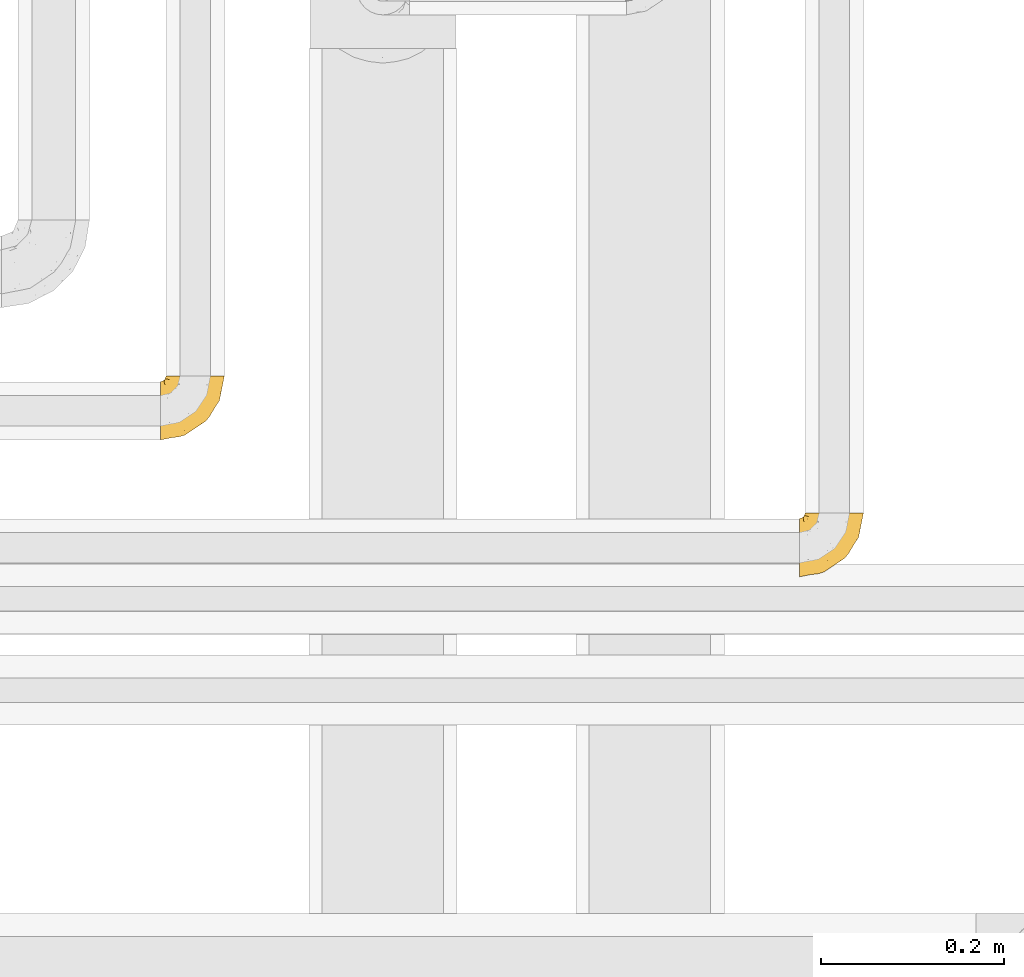
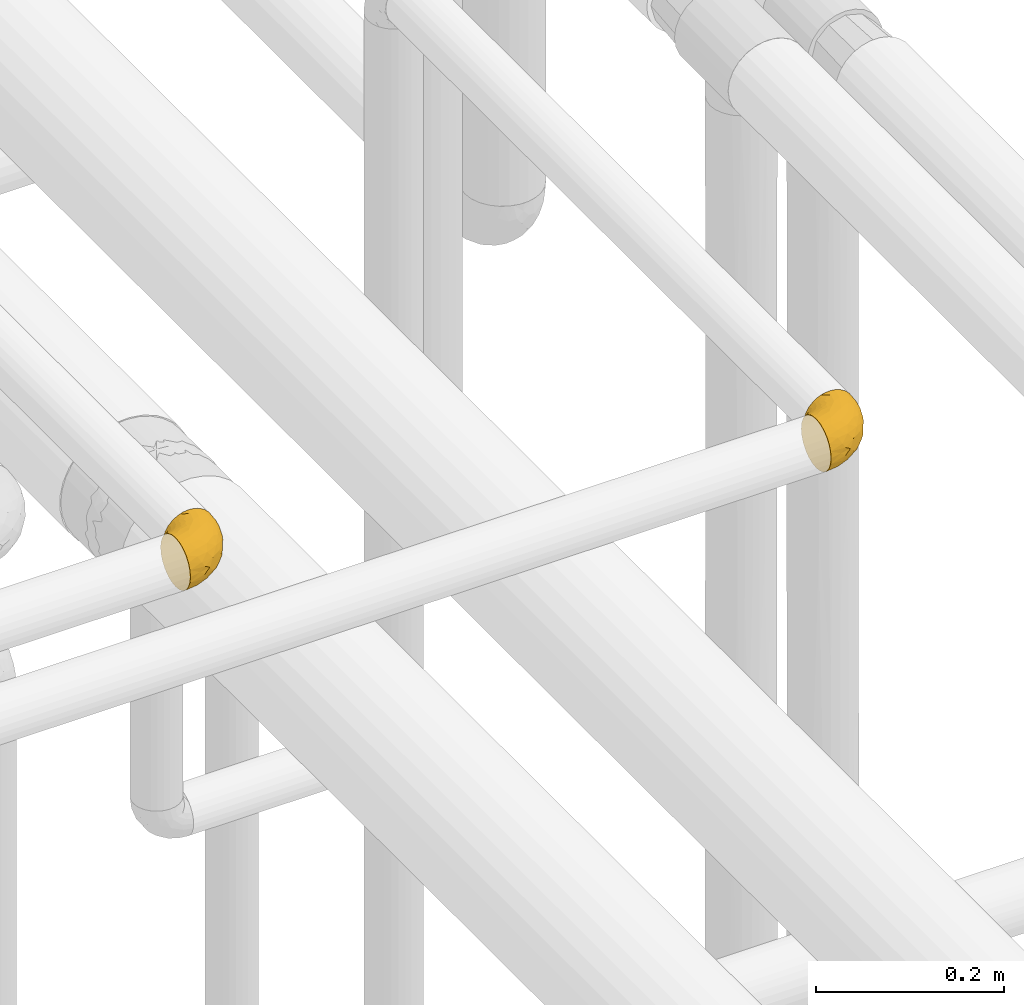
# One storey, part 495 of 827: 2 coverings.
"""IFC2X3 building model written with IfcOpenShell, lengths in millimetres."""

from ifc_helpers import new_model, entity, si_unit, converted_unit, derived_unit, direction, frame, origin, place, context, subcontext, project, spatial, faceted_brep, element, save


model = new_model("IFC2X3")

# Units and contexts
model_context = context("Model", 3, precision=0.01, world=origin(), true_north=direction((6.12303176911189e-17, 1.0)))
body_context = subcontext(model_context, "Body", "Model", "MODEL_VIEW")
ifc_project = project(units=[si_unit("LENGTHUNIT", "METRE", prefix="MILLI"), si_unit("AREAUNIT", "SQUARE_METRE"), si_unit("VOLUMEUNIT", "CUBIC_METRE"), converted_unit("PLANEANGLEUNIT", "DEGREE", entity("IfcRatioMeasure", 0.0174532925199433), si_unit("PLANEANGLEUNIT", "RADIAN"), dimensions=[0, 0, 0, 0, 0, 0, 0]), si_unit("MASSUNIT", "GRAM", prefix="KILO"), derived_unit("MASSDENSITYUNIT", [(si_unit("MASSUNIT", "GRAM", prefix="KILO"), 1), (si_unit("LENGTHUNIT", "METRE"), -3)]), derived_unit("MOMENTOFINERTIAUNIT", [(si_unit("LENGTHUNIT", "METRE"), 4)]), si_unit("TIMEUNIT", "SECOND"), si_unit("FREQUENCYUNIT", "HERTZ"), si_unit("THERMODYNAMICTEMPERATUREUNIT", "DEGREE_CELSIUS"), derived_unit("THERMALTRANSMITTANCEUNIT", [(si_unit("MASSUNIT", "GRAM", prefix="KILO"), 1), (si_unit("THERMODYNAMICTEMPERATUREUNIT", "KELVIN"), -1), (si_unit("TIMEUNIT", "SECOND"), -3)]), derived_unit("VOLUMETRICFLOWRATEUNIT", [(si_unit("LENGTHUNIT", "METRE"), 3), (si_unit("TIMEUNIT", "SECOND"), -1)]), derived_unit("MASSFLOWRATEUNIT", [(si_unit("MASSUNIT", "GRAM", prefix="KILO"), 1), (si_unit("TIMEUNIT", "SECOND"), -1)]), derived_unit("ROTATIONALFREQUENCYUNIT", [(si_unit("TIMEUNIT", "SECOND"), -1)]), si_unit("ELECTRICCURRENTUNIT", "AMPERE"), si_unit("ELECTRICVOLTAGEUNIT", "VOLT"), si_unit("POWERUNIT", "WATT"), si_unit("FORCEUNIT", "NEWTON", prefix="KILO"), si_unit("ILLUMINANCEUNIT", "LUX"), si_unit("LUMINOUSFLUXUNIT", "LUMEN"), si_unit("LUMINOUSINTENSITYUNIT", "CANDELA"), derived_unit("USERDEFINED", [(si_unit("MASSUNIT", "GRAM", prefix="KILO"), -1), (si_unit("LENGTHUNIT", "METRE"), -2), (si_unit("TIMEUNIT", "SECOND"), 3), (si_unit("LUMINOUSFLUXUNIT", "LUMEN"), 1)]), derived_unit("LINEARVELOCITYUNIT", [(si_unit("LENGTHUNIT", "METRE"), 1), (si_unit("TIMEUNIT", "SECOND"), -1)]), si_unit("PRESSUREUNIT", "PASCAL"), derived_unit("USERDEFINED", [(si_unit("LENGTHUNIT", "METRE"), -2), (si_unit("MASSUNIT", "GRAM", prefix="KILO"), 1), (si_unit("TIMEUNIT", "SECOND"), -2)]), derived_unit("LINEARFORCEUNIT", [(si_unit("MASSUNIT", "GRAM", prefix="KILO"), 1), (si_unit("LENGTHUNIT", "METRE"), 1), (si_unit("TIMEUNIT", "SECOND"), -2), (si_unit("LENGTHUNIT", "METRE"), -1)]), derived_unit("PLANARFORCEUNIT", [(si_unit("MASSUNIT", "GRAM", prefix="KILO"), 1), (si_unit("LENGTHUNIT", "METRE"), 1), (si_unit("TIMEUNIT", "SECOND"), -2), (si_unit("LENGTHUNIT", "METRE"), -2)])], contexts=[model_context])

# Site, building, storey
site_placement = place(None, origin())
site = spatial("IfcSite", under=ifc_project, at=site_placement, CompositionType="ELEMENT")
building_placement = place(site_placement, origin())
building = spatial("IfcBuilding", under=site, at=building_placement, CompositionType="ELEMENT")
storey_placement = place(building_placement, frame((0.0, 0.0, 28200.0)))
storey = spatial("IfcBuildingStorey", under=building, at=storey_placement, Name="08", CompositionType="ELEMENT", Elevation=28200.0)

# Coverings
covering_1_placement = place(storey_placement, frame((60613.54, 16502.25, 3166.55)))
element("IfcCovering", 1, at=covering_1_placement, inside=storey, Name=":ADSK_", ObjectType=":ADSK_", PredefinedType="INSULATION", context=body_context, shape_type="Brep", body=[
    faceted_brep([(70.65, 71.45, 40.53), (71.45, 71.45, 33.45), (70.65, 71.45, 26.35), (68.29, 71.45, 19.62), (64.49, 71.45, 13.58), (59.45, 71.45, 8.54), (53.41, 71.45, 4.75), (46.68, 71.45, 2.39), (39.6, 71.45, 1.6), (35.69, 71.45, 2.04), (32.5, 71.45, 2.39), (29.14, 71.45, 3.57), (25.77, 71.45, 4.75), (19.73, 71.45, 8.55), (14.69, 71.45, 13.59), (10.9, 71.45, 19.63), (8.54, 71.45, 26.36), (7.75, 71.45, 33.45), (8.54, 71.45, 40.54), (10.9, 71.45, 47.27), (14.7, 71.45, 53.31), (19.74, 71.45, 58.35), (25.78, 71.45, 62.14), (29.15, 71.45, 63.32), (32.51, 71.45, 64.5), (35.69, 71.45, 64.86), (37.64, 71.45, 65.08), (39.6, 71.45, 65.3), (46.69, 71.45, 64.5), (53.42, 71.45, 62.14), (59.46, 71.45, 58.34), (64.5, 71.45, 53.3), (68.29, 71.45, 47.26), (1.6, 49.37, 5.86), (1.6, 45.53, 4.27), (1.6, 41.69, 2.68), (1.6, 37.37, 2.11), (1.6, 35.41, 1.85), (1.6, 33.45, 1.6), (1.6, 25.2, 2.68), (1.6, 17.52, 5.86), (1.6, 10.92, 10.92), (1.6, 5.86, 17.52), (1.6, 2.68, 25.2), (1.6, 1.6, 33.45), (1.6, 2.68, 41.69), (1.6, 5.86, 49.37), (1.6, 10.92, 55.97), (1.6, 17.52, 61.03), (1.6, 25.2, 64.21), (1.6, 33.45, 65.3), (1.6, 37.37, 64.78), (1.6, 41.69, 64.21), (1.6, 45.53, 62.62), (1.6, 49.37, 61.03), (1.6, 52.67, 58.5), (1.6, 55.97, 55.97), (1.6, 61.03, 49.37), (1.6, 64.21, 41.69), (1.6, 65.3, 33.45), (1.6, 64.21, 25.2), (1.6, 61.03, 17.52), (1.6, 55.97, 10.92), (1.6, 52.67, 8.39), (35.56, 39.1, 64.03), (34.5, 52.45, 65.3), (31.03, 48.97, 65.3), (27.55, 45.49, 65.3), (24.07, 42.01, 65.3), (20.6, 38.54, 65.3), (14.96, 4.25, 33.45), (32.2, 19.42, 56.13), (25.13, 22.87, 61.0), (17.37, 14.43, 57.25), (17.86, 5.53, 44.44), (27.91, 12.01, 50.33), (13.85, 8.54, 51.72), (61.37, 55.06, 54.4), (34.87, 11.33, 41.87), (44.22, 20.79, 48.25), (43.56, 56.32, 64.6), (40.93, 33.95, 60.78), (48.36, 47.18, 61.71), (17.22, 28.97, 64.46), (44.67, 28.68, 55.78), (63.86, 41.69, 40.71), (68.09, 55.32, 42.87), (61.87, 43.59, 47.87), (12.15, 20.67, 62.12), (17.69, 37.76, 65.3), (14.79, 36.98, 65.3), (11.89, 36.2, 65.3), (8.99, 35.43, 65.3), (7.14, 34.93, 65.3), (5.29, 34.44, 65.3), (56.77, 58.97, 59.32), (66.08, 59.39, 49.35), (68.79, 58.08, 33.45), (51.2, 59.72, 62.53), (39.1, 69.6, 65.3), (38.61, 67.75, 65.3), (37.61, 64.05, 65.3), (36.84, 61.15, 65.3), (36.06, 58.25, 65.3), (35.28, 55.35, 65.3), (54.2, 43.85, 57.03), (58.65, 44.13, 52.84), (21.36, 4.87, 38.52), (66.13, 44.71, 33.45), (46.99, 19.59, 41.09), (39.66, 14.48, 33.45), (50.99, 22.05, 33.45), (55.34, 29.9, 44.35), (53.83, 33.81, 51.29), (28.33, 6.91, 33.45), (55.34, 27.44, 38.44), (58.56, 33.38, 33.45), (6.06, 55.01, 57.42), (8.03, 50.28, 61.06), (11.06, 51.09, 61.24), (8.19, 40.86, 64.58), (10.89, 43.96, 64.0), (24.37, 52.27, 64.21), (9.23, 68.29, 44.85), (22.33, 62.01, 61.42), (24.59, 66.26, 61.84), (20.19, 67.36, 59.03), (5.45, 65.34, 41.64), (7.56, 68.62, 38.8), (5.94, 67.1, 33.45), (6.36, 58.52, 54.12), (29.84, 61.41, 64.27), (28.12, 66.44, 63.33), (14.94, 65.71, 54.97), (11.12, 60.56, 54.91), (9.87, 65.05, 49.44), (6.36, 61.9, 49.79), (16.34, 58.97, 59.23), (22.18, 57.67, 62.42), (18.62, 62.23, 59.27), (32.34, 65.15, 64.6), (15.29, 46.86, 63.73), (11.7, 67.24, 50.25), (13.14, 63.1, 54.66), (15.04, 50.81, 62.35), (10.61, 54.65, 59.05), (27.21, 55.33, 64.34), (14.05, 56.17, 59.52), (27.14, 59.8, 63.71), (5.74, 48.09, 61.92), (19.92, 46.45, 64.52), (23.61, 46.88, 64.9), (19.14, 50.93, 63.33), (20.12, 55.61, 62.23), (9.23, 68.29, 22.04), (11.69, 67.24, 16.65), (9.87, 65.05, 17.46), (16.33, 58.97, 7.66), (13.17, 62.98, 12.13), (18.65, 61.5, 7.35), (5.45, 65.34, 25.25), (32.33, 65.15, 2.29), (37.61, 64.05, 1.6), (36.84, 61.15, 1.6), (36.06, 58.25, 1.6), (7.56, 68.62, 28.1), (14.85, 50.62, 4.51), (17.26, 45.09, 2.45), (10.58, 50.82, 5.62), (3.44, 33.94, 1.6), (11.89, 36.2, 1.6), (8.99, 35.43, 1.6), (5.29, 34.44, 1.6), (5.65, 51.55, 6.96), (6.88, 46.52, 4.16), (14.93, 54.95, 6.38), (10.6, 54.65, 7.84), (11.09, 59.16, 10.87), (6.36, 61.9, 17.1), (8.19, 40.86, 2.31), (20.6, 38.54, 1.6), (24.07, 42.01, 1.6), (29.86, 61.39, 2.62), (20.16, 67.37, 7.88), (24.58, 66.23, 5.05), (38.61, 67.75, 1.6), (38.11, 65.9, 1.6), (14.93, 65.7, 11.92), (14.79, 36.98, 1.6), (12.32, 41.66, 2.23), (23.91, 53.21, 2.95), (27.55, 45.49, 1.6), (19.33, 50.1, 3.29), (28.11, 66.44, 3.56), (6.0, 55.11, 9.57), (6.44, 58.52, 12.74), (28.13, 55.59, 2.39), (22.32, 62.01, 5.47), (35.28, 55.35, 1.6), (34.5, 52.45, 1.6), (26.65, 60.71, 3.46), (15.34, 42.77, 2.2), (17.69, 37.76, 1.6), (10.31, 47.15, 4.02), (31.03, 48.97, 1.6), (17.37, 14.42, 9.64), (51.19, 59.72, 4.35), (43.56, 56.32, 2.29), (17.22, 28.97, 2.43), (34.87, 11.33, 25.02), (17.86, 5.53, 22.45), (27.92, 12.01, 16.56), (25.12, 22.86, 5.89), (35.57, 39.12, 2.86), (40.93, 33.96, 6.1), (32.19, 19.42, 10.76), (21.36, 4.87, 28.37), (12.15, 20.67, 4.77), (13.85, 8.55, 15.17), (48.35, 47.18, 5.18), (56.76, 58.97, 7.56), (54.19, 43.86, 9.85), (61.86, 43.58, 19.01), (68.09, 55.32, 24.01), (63.85, 41.67, 26.18), (61.36, 55.05, 12.48), (47.0, 19.59, 25.8), (53.81, 33.79, 15.6), (58.64, 44.12, 14.04), (66.07, 59.39, 17.53), (44.24, 20.81, 18.64), (55.34, 29.91, 22.54), (44.67, 28.68, 11.1), (55.34, 27.45, 28.45)], [[[0, 1, 2, 3, 4, 5, 6, 7, 8, 9, 10, 11, 12, 13, 14, 15, 16, 17, 18, 19, 20, 21, 22, 23, 24, 25, 26, 27, 28, 29, 30, 31, 32]], [[33, 34, 35, 36, 37, 38, 39, 40, 41, 42, 43, 44, 45, 46, 47, 48, 49, 50, 51, 52, 53, 54, 55, 56, 57, 58, 59, 60, 61, 62, 63]], [[64, 65, 66, 67, 68, 69]], [[45, 44, 70]], [[71, 72, 73]], [[74, 75, 76]], [[77, 31, 30]], [[75, 78, 79]], [[27, 80, 28]], [[74, 46, 45]], [[64, 81, 82]], [[46, 76, 47]], [[83, 50, 49]], [[48, 47, 73]], [[71, 79, 84]], [[85, 86, 87]], [[49, 48, 88]], [[83, 69, 89, 90, 91, 92, 93, 94, 50]], [[95, 77, 30]], [[75, 74, 78]], [[87, 86, 96]], [[96, 86, 32]], [[96, 32, 31]], [[0, 86, 97]], [[83, 64, 69]], [[98, 80, 82]], [[73, 72, 88]], [[64, 80, 65]], [[1, 0, 97]], [[80, 27, 99, 100, 101, 102, 103, 104, 65]], [[77, 105, 106]], [[64, 82, 80]], [[70, 107, 45]], [[77, 95, 105]], [[82, 95, 98]], [[95, 30, 29]], [[74, 107, 78]], [[86, 0, 32]], [[72, 71, 81]], [[85, 108, 86]], [[76, 73, 47]], [[71, 84, 81]], [[109, 110, 111]], [[87, 112, 85]], [[79, 109, 112]], [[79, 112, 113]], [[88, 83, 49]], [[64, 83, 72]], [[31, 77, 96]], [[87, 96, 77]], [[98, 95, 29]], [[105, 95, 82]], [[81, 105, 82]], [[105, 84, 113]], [[29, 28, 98]], [[114, 107, 70]], [[80, 98, 28]], [[73, 75, 71]], [[79, 71, 75]], [[74, 76, 46]], [[73, 76, 75]], [[78, 107, 114]], [[45, 107, 74]], [[87, 113, 112]], [[115, 85, 112]], [[109, 79, 78]], [[113, 87, 106]], [[116, 115, 111]], [[116, 108, 85]], [[79, 113, 84]], [[109, 78, 110]], [[115, 109, 111]], [[85, 115, 116]], [[109, 115, 112]], [[72, 81, 64]], [[105, 81, 84]], [[73, 88, 48]], [[83, 88, 72]], [[86, 108, 97]], [[78, 114, 110]], [[113, 106, 105]], [[87, 77, 106]], [[117, 118, 119]], [[52, 120, 54, 53]], [[91, 120, 52]], [[91, 90, 120]], [[90, 121, 120]], [[122, 67, 66]], [[18, 123, 19]], [[124, 125, 126]], [[127, 59, 58]], [[128, 129, 127]], [[130, 57, 117]], [[131, 132, 125]], [[19, 133, 20]], [[128, 18, 17]], [[134, 135, 136]], [[137, 138, 139]], [[131, 103, 140]], [[22, 140, 23]], [[131, 65, 104, 103]], [[99, 27, 26, 25, 24, 101, 100]], [[141, 118, 121]], [[19, 123, 142]], [[52, 51, 50, 94, 93, 92, 91]], [[129, 128, 17]], [[117, 56, 118]], [[135, 134, 143]], [[139, 126, 133]], [[119, 144, 145]], [[127, 135, 123]], [[136, 58, 57]], [[101, 24, 23]], [[124, 138, 146]], [[140, 101, 23]], [[145, 147, 134]], [[140, 132, 131]], [[140, 103, 102, 101]], [[140, 22, 132]], [[146, 148, 124]], [[121, 69, 141]], [[55, 149, 118]], [[150, 151, 152]], [[147, 137, 134]], [[144, 150, 152]], [[152, 151, 122]], [[138, 122, 146]], [[59, 127, 129]], [[123, 18, 128]], [[58, 136, 127]], [[135, 127, 136]], [[121, 90, 89, 69]], [[120, 121, 149]], [[122, 66, 146]], [[153, 122, 138]], [[141, 69, 68]], [[127, 123, 128]], [[123, 135, 142]], [[143, 142, 135]], [[19, 142, 133]], [[66, 65, 146]], [[148, 65, 131]], [[22, 21, 132]], [[125, 132, 21]], [[126, 125, 21]], [[148, 125, 124]], [[21, 20, 126]], [[133, 126, 20]], [[139, 138, 124]], [[153, 138, 137]], [[126, 139, 124]], [[139, 133, 143]], [[147, 153, 137]], [[152, 122, 153]], [[134, 136, 130]], [[137, 139, 143]], [[144, 147, 145]], [[153, 147, 152]], [[65, 148, 146]], [[125, 148, 131]], [[141, 144, 119]], [[55, 54, 149]], [[137, 143, 134]], [[142, 143, 133]], [[130, 117, 145]], [[57, 56, 117]], [[134, 130, 145]], [[57, 130, 136]], [[150, 144, 141]], [[147, 144, 152]], [[141, 68, 150]], [[151, 68, 67]], [[117, 119, 145]], [[141, 119, 118]], [[68, 151, 150]], [[122, 151, 67]], [[118, 56, 55]], [[120, 149, 54]], [[118, 149, 121]], [[154, 155, 156]], [[157, 158, 159]], [[129, 160, 59]], [[161, 162, 163, 164]], [[165, 160, 129]], [[166, 167, 168]], [[169, 38, 37, 36, 35, 170, 171, 172]], [[63, 173, 174]], [[175, 176, 177]], [[60, 178, 61]], [[179, 35, 34, 33]], [[160, 60, 59]], [[180, 167, 181]], [[129, 17, 165]], [[182, 161, 164]], [[183, 13, 184]], [[9, 8, 185, 186, 162, 10]], [[187, 155, 15]], [[188, 179, 189]], [[187, 15, 14]], [[190, 191, 192]], [[182, 193, 161]], [[194, 176, 168]], [[176, 195, 177]], [[196, 190, 197]], [[11, 10, 162]], [[11, 161, 12]], [[187, 14, 183]], [[12, 161, 193]], [[156, 158, 177]], [[165, 17, 16]], [[194, 195, 176]], [[187, 159, 158]], [[179, 174, 189]], [[182, 164, 198, 199]], [[200, 199, 196]], [[193, 184, 13]], [[194, 168, 173]], [[201, 202, 189]], [[16, 154, 165]], [[160, 156, 178]], [[160, 165, 154]], [[178, 60, 160]], [[170, 35, 179]], [[188, 170, 179]], [[189, 174, 203]], [[174, 179, 33]], [[201, 189, 203]], [[181, 192, 191]], [[167, 180, 201]], [[192, 175, 190]], [[159, 190, 157]], [[15, 154, 16]], [[204, 196, 199]], [[204, 191, 190]], [[160, 154, 156]], [[15, 155, 154]], [[158, 155, 187]], [[203, 173, 168]], [[192, 181, 167]], [[190, 196, 204]], [[200, 196, 197]], [[184, 193, 182]], [[13, 12, 193]], [[200, 184, 182]], [[184, 200, 183]], [[187, 183, 197]], [[14, 13, 183]], [[162, 161, 11]], [[63, 62, 173]], [[174, 33, 63]], [[173, 62, 194]], [[174, 173, 203]], [[62, 61, 194]], [[195, 61, 178]], [[61, 195, 194]], [[177, 195, 178]], [[156, 177, 178]], [[175, 192, 166]], [[166, 168, 176]], [[167, 203, 168]], [[175, 166, 176]], [[167, 166, 192]], [[177, 157, 175]], [[190, 175, 157]], [[187, 197, 159]], [[190, 159, 197]], [[177, 158, 157]], [[155, 158, 156]], [[167, 201, 203]], [[200, 197, 183]], [[202, 201, 180]], [[202, 188, 189]], [[199, 200, 182]], [[41, 40, 205]], [[206, 207, 7]], [[208, 38, 169, 172, 171, 170, 188, 202, 180]], [[209, 210, 211]], [[212, 213, 214]], [[212, 215, 205]], [[43, 210, 216]], [[217, 40, 39]], [[216, 114, 70]], [[208, 213, 212]], [[205, 40, 217]], [[218, 42, 41]], [[216, 209, 114]], [[42, 218, 210]], [[214, 213, 219]], [[219, 220, 221]], [[199, 207, 213]], [[213, 207, 219]], [[8, 7, 207]], [[222, 223, 224]], [[4, 225, 5]], [[2, 97, 223]], [[110, 226, 111]], [[225, 220, 5]], [[227, 221, 228]], [[223, 229, 3]], [[2, 223, 3]], [[230, 231, 226]], [[224, 223, 108]], [[42, 210, 43]], [[230, 209, 211]], [[222, 225, 229]], [[38, 208, 39]], [[3, 229, 4]], [[213, 180, 181, 191, 204, 199]], [[220, 206, 6]], [[5, 220, 6]], [[207, 199, 198, 164, 163, 162, 186, 185, 8]], [[212, 214, 215]], [[218, 205, 211]], [[211, 215, 230]], [[226, 110, 209]], [[222, 231, 227]], [[222, 224, 231]], [[213, 208, 180]], [[217, 208, 212]], [[222, 229, 223]], [[225, 4, 229]], [[221, 220, 225]], [[206, 220, 219]], [[228, 221, 225]], [[214, 221, 232]], [[207, 206, 219]], [[44, 43, 70]], [[7, 6, 206]], [[230, 215, 232]], [[211, 205, 215]], [[205, 218, 41]], [[210, 218, 211]], [[43, 216, 70]], [[209, 216, 210]], [[233, 116, 111]], [[230, 232, 227]], [[224, 116, 233]], [[230, 226, 209]], [[224, 108, 116]], [[230, 227, 231]], [[221, 227, 232]], [[233, 226, 231]], [[225, 222, 228]], [[226, 233, 111]], [[224, 233, 231]], [[221, 214, 219]], [[214, 232, 215]], [[208, 217, 39]], [[205, 217, 212]], [[97, 2, 1]], [[97, 108, 223]], [[110, 114, 209]], [[227, 228, 222]]]),
])
covering_2_placement = place(storey_placement, frame((59913.54, 16652.25, 3166.55)))
element("IfcCovering", 2, at=covering_2_placement, inside=storey, Name=":ADSK_", ObjectType=":ADSK_", PredefinedType="INSULATION", context=body_context, shape_type="Brep", body=[
    faceted_brep([(70.65, 71.45, 40.53), (71.45, 71.45, 33.45), (70.65, 71.45, 26.35), (68.29, 71.45, 19.62), (64.49, 71.45, 13.58), (59.45, 71.45, 8.54), (53.41, 71.45, 4.75), (46.68, 71.45, 2.39), (39.6, 71.45, 1.6), (35.69, 71.45, 2.04), (32.5, 71.45, 2.39), (29.14, 71.45, 3.57), (25.77, 71.45, 4.75), (19.73, 71.45, 8.55), (14.69, 71.45, 13.59), (10.9, 71.45, 19.63), (8.54, 71.45, 26.36), (7.75, 71.45, 33.45), (8.54, 71.45, 40.54), (10.9, 71.45, 47.27), (14.7, 71.45, 53.31), (19.74, 71.45, 58.35), (25.78, 71.45, 62.14), (29.15, 71.45, 63.32), (32.51, 71.45, 64.5), (35.69, 71.45, 64.86), (37.64, 71.45, 65.08), (39.6, 71.45, 65.3), (46.69, 71.45, 64.5), (53.42, 71.45, 62.14), (59.46, 71.45, 58.34), (64.5, 71.45, 53.3), (68.29, 71.45, 47.26), (1.6, 49.37, 5.86), (1.6, 45.53, 4.27), (1.6, 41.69, 2.68), (1.6, 37.37, 2.11), (1.6, 35.41, 1.85), (1.6, 33.45, 1.6), (1.6, 25.2, 2.68), (1.6, 17.52, 5.86), (1.6, 10.92, 10.92), (1.6, 5.86, 17.52), (1.6, 2.68, 25.2), (1.6, 1.6, 33.45), (1.6, 2.68, 41.69), (1.6, 5.86, 49.37), (1.6, 10.92, 55.97), (1.6, 17.52, 61.03), (1.6, 25.2, 64.21), (1.6, 33.45, 65.3), (1.6, 37.37, 64.78), (1.6, 41.69, 64.21), (1.6, 45.53, 62.62), (1.6, 49.37, 61.03), (1.6, 52.67, 58.5), (1.6, 55.97, 55.97), (1.6, 61.03, 49.37), (1.6, 64.21, 41.69), (1.6, 65.3, 33.45), (1.6, 64.21, 25.2), (1.6, 61.03, 17.52), (1.6, 55.97, 10.92), (1.6, 52.67, 8.39), (35.56, 39.1, 64.03), (34.5, 52.45, 65.3), (31.03, 48.97, 65.3), (27.55, 45.49, 65.3), (24.07, 42.01, 65.3), (20.6, 38.54, 65.3), (14.96, 4.25, 33.45), (32.2, 19.42, 56.13), (25.13, 22.87, 61.0), (17.37, 14.43, 57.25), (17.86, 5.53, 44.44), (27.91, 12.01, 50.33), (13.85, 8.54, 51.72), (61.37, 55.06, 54.4), (34.87, 11.33, 41.87), (44.22, 20.79, 48.25), (43.56, 56.32, 64.6), (40.93, 33.95, 60.78), (48.36, 47.18, 61.71), (17.22, 28.97, 64.46), (44.67, 28.68, 55.78), (63.86, 41.69, 40.71), (68.09, 55.32, 42.87), (61.87, 43.59, 47.87), (12.15, 20.67, 62.12), (17.69, 37.76, 65.3), (14.79, 36.98, 65.3), (11.89, 36.2, 65.3), (8.99, 35.43, 65.3), (7.14, 34.93, 65.3), (5.29, 34.44, 65.3), (56.77, 58.97, 59.32), (66.08, 59.39, 49.35), (68.79, 58.08, 33.45), (51.2, 59.72, 62.53), (39.1, 69.6, 65.3), (38.61, 67.75, 65.3), (37.61, 64.05, 65.3), (36.84, 61.15, 65.3), (36.06, 58.25, 65.3), (35.28, 55.35, 65.3), (54.2, 43.85, 57.03), (58.65, 44.13, 52.84), (21.36, 4.87, 38.52), (66.13, 44.71, 33.45), (46.99, 19.59, 41.09), (39.66, 14.48, 33.45), (50.99, 22.05, 33.45), (55.34, 29.9, 44.35), (53.83, 33.81, 51.29), (28.33, 6.91, 33.45), (55.34, 27.44, 38.44), (58.56, 33.38, 33.45), (6.06, 55.01, 57.42), (8.03, 50.28, 61.06), (11.06, 51.09, 61.24), (8.19, 40.86, 64.58), (10.89, 43.96, 64.0), (24.37, 52.27, 64.21), (9.23, 68.29, 44.85), (22.33, 62.01, 61.42), (24.59, 66.26, 61.84), (20.19, 67.36, 59.03), (5.45, 65.34, 41.64), (7.56, 68.62, 38.8), (5.94, 67.1, 33.45), (6.36, 58.52, 54.12), (29.84, 61.41, 64.27), (28.12, 66.44, 63.33), (14.94, 65.71, 54.97), (11.12, 60.56, 54.91), (9.87, 65.05, 49.44), (6.36, 61.9, 49.79), (16.34, 58.97, 59.23), (22.18, 57.67, 62.42), (18.62, 62.23, 59.27), (32.34, 65.15, 64.6), (15.29, 46.86, 63.73), (11.7, 67.24, 50.25), (13.14, 63.1, 54.66), (15.04, 50.81, 62.35), (10.61, 54.65, 59.05), (27.21, 55.33, 64.34), (14.05, 56.17, 59.52), (27.14, 59.8, 63.71), (5.74, 48.09, 61.92), (19.92, 46.45, 64.52), (23.61, 46.88, 64.9), (19.14, 50.93, 63.33), (20.12, 55.61, 62.23), (9.23, 68.29, 22.04), (11.69, 67.24, 16.65), (9.87, 65.05, 17.46), (16.33, 58.97, 7.66), (13.17, 62.98, 12.13), (18.65, 61.5, 7.35), (5.45, 65.34, 25.25), (32.33, 65.15, 2.29), (37.61, 64.05, 1.6), (36.84, 61.15, 1.6), (36.06, 58.25, 1.6), (7.56, 68.62, 28.1), (14.85, 50.62, 4.51), (17.26, 45.09, 2.45), (10.58, 50.82, 5.62), (3.44, 33.94, 1.6), (11.89, 36.2, 1.6), (8.99, 35.43, 1.6), (5.29, 34.44, 1.6), (5.65, 51.55, 6.96), (6.88, 46.52, 4.16), (14.93, 54.95, 6.38), (10.6, 54.65, 7.84), (11.09, 59.16, 10.87), (6.36, 61.9, 17.1), (8.19, 40.86, 2.31), (20.6, 38.54, 1.6), (24.07, 42.01, 1.6), (29.86, 61.39, 2.62), (20.16, 67.37, 7.88), (24.58, 66.23, 5.05), (38.61, 67.75, 1.6), (38.11, 65.9, 1.6), (14.93, 65.7, 11.92), (14.79, 36.98, 1.6), (12.32, 41.66, 2.23), (23.91, 53.21, 2.95), (27.55, 45.49, 1.6), (19.33, 50.1, 3.29), (28.11, 66.44, 3.56), (6.0, 55.11, 9.57), (6.44, 58.52, 12.74), (28.13, 55.59, 2.39), (22.32, 62.01, 5.47), (35.28, 55.35, 1.6), (34.5, 52.45, 1.6), (26.65, 60.71, 3.46), (15.34, 42.77, 2.2), (17.69, 37.76, 1.6), (10.31, 47.15, 4.02), (31.03, 48.97, 1.6), (17.37, 14.42, 9.64), (51.19, 59.72, 4.35), (43.56, 56.32, 2.29), (17.22, 28.97, 2.43), (34.87, 11.33, 25.02), (17.86, 5.53, 22.45), (27.92, 12.01, 16.56), (25.12, 22.86, 5.89), (35.57, 39.12, 2.86), (40.93, 33.96, 6.1), (32.19, 19.42, 10.76), (21.36, 4.87, 28.37), (12.15, 20.67, 4.77), (13.85, 8.55, 15.17), (48.35, 47.18, 5.18), (56.76, 58.97, 7.56), (54.19, 43.86, 9.85), (61.86, 43.58, 19.01), (68.09, 55.32, 24.01), (63.85, 41.67, 26.18), (61.36, 55.05, 12.48), (47.0, 19.59, 25.8), (53.81, 33.79, 15.6), (58.64, 44.12, 14.04), (66.07, 59.39, 17.53), (44.24, 20.81, 18.64), (55.34, 29.91, 22.54), (44.67, 28.68, 11.1), (55.34, 27.45, 28.45)], [[[0, 1, 2, 3, 4, 5, 6, 7, 8, 9, 10, 11, 12, 13, 14, 15, 16, 17, 18, 19, 20, 21, 22, 23, 24, 25, 26, 27, 28, 29, 30, 31, 32]], [[33, 34, 35, 36, 37, 38, 39, 40, 41, 42, 43, 44, 45, 46, 47, 48, 49, 50, 51, 52, 53, 54, 55, 56, 57, 58, 59, 60, 61, 62, 63]], [[64, 65, 66, 67, 68, 69]], [[45, 44, 70]], [[71, 72, 73]], [[74, 75, 76]], [[77, 31, 30]], [[75, 78, 79]], [[27, 80, 28]], [[74, 46, 45]], [[64, 81, 82]], [[46, 76, 47]], [[83, 50, 49]], [[48, 47, 73]], [[71, 79, 84]], [[85, 86, 87]], [[49, 48, 88]], [[83, 69, 89, 90, 91, 92, 93, 94, 50]], [[95, 77, 30]], [[75, 74, 78]], [[87, 86, 96]], [[96, 86, 32]], [[96, 32, 31]], [[0, 86, 97]], [[83, 64, 69]], [[98, 80, 82]], [[73, 72, 88]], [[64, 80, 65]], [[1, 0, 97]], [[80, 27, 99, 100, 101, 102, 103, 104, 65]], [[77, 105, 106]], [[64, 82, 80]], [[70, 107, 45]], [[77, 95, 105]], [[82, 95, 98]], [[95, 30, 29]], [[74, 107, 78]], [[86, 0, 32]], [[72, 71, 81]], [[85, 108, 86]], [[76, 73, 47]], [[71, 84, 81]], [[109, 110, 111]], [[87, 112, 85]], [[79, 109, 112]], [[79, 112, 113]], [[88, 83, 49]], [[64, 83, 72]], [[31, 77, 96]], [[87, 96, 77]], [[98, 95, 29]], [[105, 95, 82]], [[81, 105, 82]], [[105, 84, 113]], [[29, 28, 98]], [[114, 107, 70]], [[80, 98, 28]], [[73, 75, 71]], [[79, 71, 75]], [[74, 76, 46]], [[73, 76, 75]], [[78, 107, 114]], [[45, 107, 74]], [[87, 113, 112]], [[115, 85, 112]], [[109, 79, 78]], [[113, 87, 106]], [[116, 115, 111]], [[116, 108, 85]], [[79, 113, 84]], [[109, 78, 110]], [[115, 109, 111]], [[85, 115, 116]], [[109, 115, 112]], [[72, 81, 64]], [[105, 81, 84]], [[73, 88, 48]], [[83, 88, 72]], [[86, 108, 97]], [[78, 114, 110]], [[113, 106, 105]], [[87, 77, 106]], [[117, 118, 119]], [[52, 120, 54, 53]], [[91, 120, 52]], [[91, 90, 120]], [[90, 121, 120]], [[122, 67, 66]], [[18, 123, 19]], [[124, 125, 126]], [[127, 59, 58]], [[128, 129, 127]], [[130, 57, 117]], [[131, 132, 125]], [[19, 133, 20]], [[128, 18, 17]], [[134, 135, 136]], [[137, 138, 139]], [[131, 103, 140]], [[22, 140, 23]], [[131, 65, 104, 103]], [[99, 27, 26, 25, 24, 101, 100]], [[141, 118, 121]], [[19, 123, 142]], [[52, 51, 50, 94, 93, 92, 91]], [[129, 128, 17]], [[117, 56, 118]], [[135, 134, 143]], [[139, 126, 133]], [[119, 144, 145]], [[127, 135, 123]], [[136, 58, 57]], [[101, 24, 23]], [[124, 138, 146]], [[140, 101, 23]], [[145, 147, 134]], [[140, 132, 131]], [[140, 103, 102, 101]], [[140, 22, 132]], [[146, 148, 124]], [[121, 69, 141]], [[55, 149, 118]], [[150, 151, 152]], [[147, 137, 134]], [[144, 150, 152]], [[152, 151, 122]], [[138, 122, 146]], [[59, 127, 129]], [[123, 18, 128]], [[58, 136, 127]], [[135, 127, 136]], [[121, 90, 89, 69]], [[120, 121, 149]], [[122, 66, 146]], [[153, 122, 138]], [[141, 69, 68]], [[127, 123, 128]], [[123, 135, 142]], [[143, 142, 135]], [[19, 142, 133]], [[66, 65, 146]], [[148, 65, 131]], [[22, 21, 132]], [[125, 132, 21]], [[126, 125, 21]], [[148, 125, 124]], [[21, 20, 126]], [[133, 126, 20]], [[139, 138, 124]], [[153, 138, 137]], [[126, 139, 124]], [[139, 133, 143]], [[147, 153, 137]], [[152, 122, 153]], [[134, 136, 130]], [[137, 139, 143]], [[144, 147, 145]], [[153, 147, 152]], [[65, 148, 146]], [[125, 148, 131]], [[141, 144, 119]], [[55, 54, 149]], [[137, 143, 134]], [[142, 143, 133]], [[130, 117, 145]], [[57, 56, 117]], [[134, 130, 145]], [[57, 130, 136]], [[150, 144, 141]], [[147, 144, 152]], [[141, 68, 150]], [[151, 68, 67]], [[117, 119, 145]], [[141, 119, 118]], [[68, 151, 150]], [[122, 151, 67]], [[118, 56, 55]], [[120, 149, 54]], [[118, 149, 121]], [[154, 155, 156]], [[157, 158, 159]], [[129, 160, 59]], [[161, 162, 163, 164]], [[165, 160, 129]], [[166, 167, 168]], [[169, 38, 37, 36, 35, 170, 171, 172]], [[63, 173, 174]], [[175, 176, 177]], [[60, 178, 61]], [[179, 35, 34, 33]], [[160, 60, 59]], [[180, 167, 181]], [[129, 17, 165]], [[182, 161, 164]], [[183, 13, 184]], [[9, 8, 185, 186, 162, 10]], [[187, 155, 15]], [[188, 179, 189]], [[187, 15, 14]], [[190, 191, 192]], [[182, 193, 161]], [[194, 176, 168]], [[176, 195, 177]], [[196, 190, 197]], [[11, 10, 162]], [[11, 161, 12]], [[187, 14, 183]], [[12, 161, 193]], [[156, 158, 177]], [[165, 17, 16]], [[194, 195, 176]], [[187, 159, 158]], [[179, 174, 189]], [[182, 164, 198, 199]], [[200, 199, 196]], [[193, 184, 13]], [[194, 168, 173]], [[201, 202, 189]], [[16, 154, 165]], [[160, 156, 178]], [[160, 165, 154]], [[178, 60, 160]], [[170, 35, 179]], [[188, 170, 179]], [[189, 174, 203]], [[174, 179, 33]], [[201, 189, 203]], [[181, 192, 191]], [[167, 180, 201]], [[192, 175, 190]], [[159, 190, 157]], [[15, 154, 16]], [[204, 196, 199]], [[204, 191, 190]], [[160, 154, 156]], [[15, 155, 154]], [[158, 155, 187]], [[203, 173, 168]], [[192, 181, 167]], [[190, 196, 204]], [[200, 196, 197]], [[184, 193, 182]], [[13, 12, 193]], [[200, 184, 182]], [[184, 200, 183]], [[187, 183, 197]], [[14, 13, 183]], [[162, 161, 11]], [[63, 62, 173]], [[174, 33, 63]], [[173, 62, 194]], [[174, 173, 203]], [[62, 61, 194]], [[195, 61, 178]], [[61, 195, 194]], [[177, 195, 178]], [[156, 177, 178]], [[175, 192, 166]], [[166, 168, 176]], [[167, 203, 168]], [[175, 166, 176]], [[167, 166, 192]], [[177, 157, 175]], [[190, 175, 157]], [[187, 197, 159]], [[190, 159, 197]], [[177, 158, 157]], [[155, 158, 156]], [[167, 201, 203]], [[200, 197, 183]], [[202, 201, 180]], [[202, 188, 189]], [[199, 200, 182]], [[41, 40, 205]], [[206, 207, 7]], [[208, 38, 169, 172, 171, 170, 188, 202, 180]], [[209, 210, 211]], [[212, 213, 214]], [[212, 215, 205]], [[43, 210, 216]], [[217, 40, 39]], [[216, 114, 70]], [[208, 213, 212]], [[205, 40, 217]], [[218, 42, 41]], [[216, 209, 114]], [[42, 218, 210]], [[214, 213, 219]], [[219, 220, 221]], [[199, 207, 213]], [[213, 207, 219]], [[8, 7, 207]], [[222, 223, 224]], [[4, 225, 5]], [[2, 97, 223]], [[110, 226, 111]], [[225, 220, 5]], [[227, 221, 228]], [[223, 229, 3]], [[2, 223, 3]], [[230, 231, 226]], [[224, 223, 108]], [[42, 210, 43]], [[230, 209, 211]], [[222, 225, 229]], [[38, 208, 39]], [[3, 229, 4]], [[213, 180, 181, 191, 204, 199]], [[220, 206, 6]], [[5, 220, 6]], [[207, 199, 198, 164, 163, 162, 186, 185, 8]], [[212, 214, 215]], [[218, 205, 211]], [[211, 215, 230]], [[226, 110, 209]], [[222, 231, 227]], [[222, 224, 231]], [[213, 208, 180]], [[217, 208, 212]], [[222, 229, 223]], [[225, 4, 229]], [[221, 220, 225]], [[206, 220, 219]], [[228, 221, 225]], [[214, 221, 232]], [[207, 206, 219]], [[44, 43, 70]], [[7, 6, 206]], [[230, 215, 232]], [[211, 205, 215]], [[205, 218, 41]], [[210, 218, 211]], [[43, 216, 70]], [[209, 216, 210]], [[233, 116, 111]], [[230, 232, 227]], [[224, 116, 233]], [[230, 226, 209]], [[224, 108, 116]], [[230, 227, 231]], [[221, 227, 232]], [[233, 226, 231]], [[225, 222, 228]], [[226, 233, 111]], [[224, 233, 231]], [[221, 214, 219]], [[214, 232, 215]], [[208, 217, 39]], [[205, 217, 212]], [[97, 2, 1]], [[97, 108, 223]], [[110, 114, 209]], [[227, 228, 222]]]),
])

save(model, "model.ifc")
